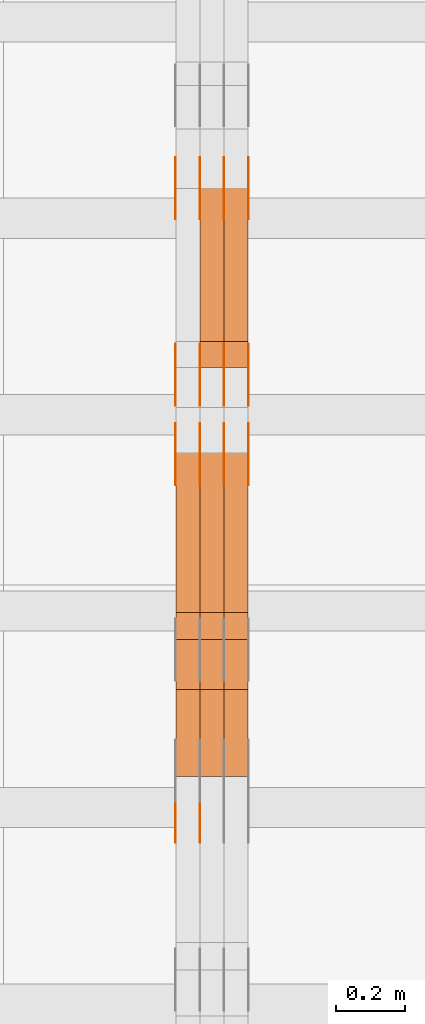
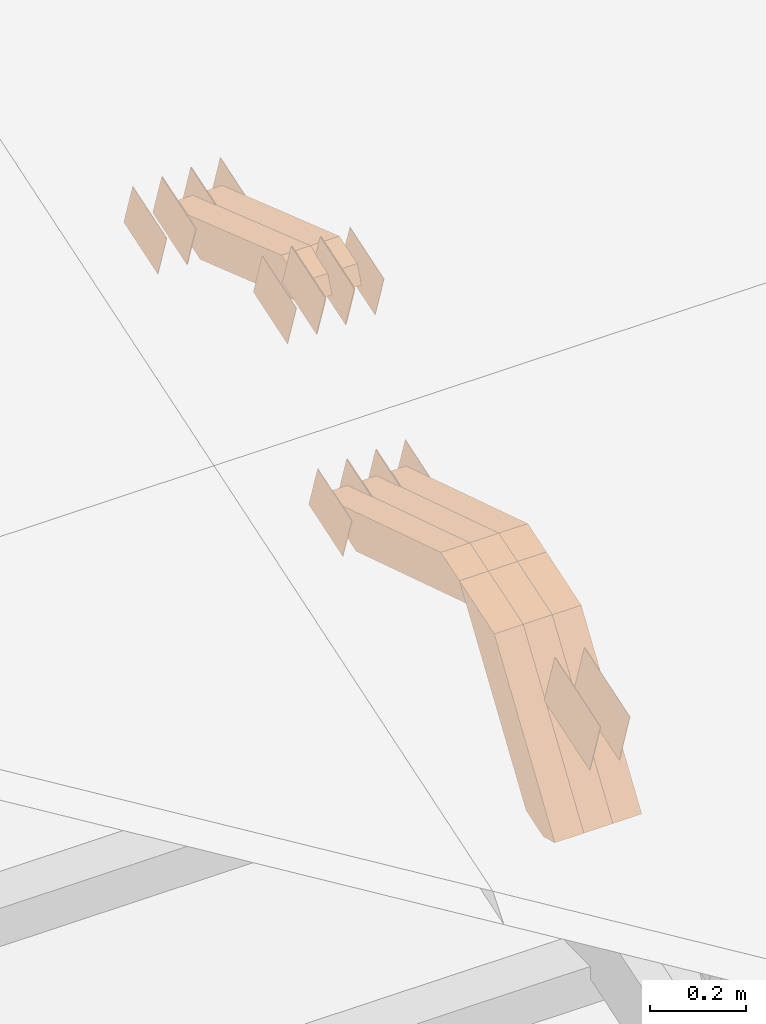
# One storey, part 269 of 385: 28 proxies.
"""IFC2X3 building model written with IfcOpenShell, lengths in millimetres."""

from ifc_helpers import new_model, entity, si_unit, converted_unit, derived_unit, direction, frame, origin, place, context, subcontext, project, spatial, polyline, outline, extrude, source, transform, mapped, material, type_object, type_shapes, element, save


model = new_model("IFC2X3")

# Units and contexts
model_context = context("Model", 3, precision=0.01, world=origin(), true_north=direction((6.12303176911189e-17, 1.0)))
body_context = subcontext(model_context, "Body", "Model", "MODEL_VIEW")
ifc_project = project(units=[si_unit("LENGTHUNIT", "METRE", prefix="MILLI"), si_unit("AREAUNIT", "SQUARE_METRE"), si_unit("VOLUMEUNIT", "CUBIC_METRE"), converted_unit("PLANEANGLEUNIT", "DEGREE", entity("IfcRatioMeasure", 0.0174532925199433), si_unit("PLANEANGLEUNIT", "RADIAN"), dimensions=[0, 0, 0, 0, 0, 0, 0]), si_unit("MASSUNIT", "GRAM", prefix="KILO"), derived_unit("MASSDENSITYUNIT", [(si_unit("MASSUNIT", "GRAM", prefix="KILO"), 1), (si_unit("LENGTHUNIT", "METRE"), -3)]), si_unit("TIMEUNIT", "SECOND"), si_unit("FREQUENCYUNIT", "HERTZ"), si_unit("THERMODYNAMICTEMPERATUREUNIT", "DEGREE_CELSIUS"), derived_unit("THERMALTRANSMITTANCEUNIT", [(si_unit("MASSUNIT", "GRAM", prefix="KILO"), 1), (si_unit("THERMODYNAMICTEMPERATUREUNIT", "KELVIN"), -1), (si_unit("TIMEUNIT", "SECOND"), -3)]), derived_unit("VOLUMETRICFLOWRATEUNIT", [(si_unit("LENGTHUNIT", "METRE"), 3), (si_unit("TIMEUNIT", "SECOND"), -1)]), si_unit("ELECTRICCURRENTUNIT", "AMPERE"), si_unit("ELECTRICVOLTAGEUNIT", "VOLT"), si_unit("POWERUNIT", "WATT"), si_unit("FORCEUNIT", "NEWTON", prefix="KILO"), si_unit("ILLUMINANCEUNIT", "LUX"), si_unit("LUMINOUSFLUXUNIT", "LUMEN"), si_unit("LUMINOUSINTENSITYUNIT", "CANDELA"), derived_unit("USERDEFINED", [(si_unit("MASSUNIT", "GRAM", prefix="KILO"), -1), (si_unit("LENGTHUNIT", "METRE"), -2), (si_unit("TIMEUNIT", "SECOND"), 3), (si_unit("LUMINOUSFLUXUNIT", "LUMEN"), 1)]), derived_unit("LINEARVELOCITYUNIT", [(si_unit("LENGTHUNIT", "METRE"), 1), (si_unit("TIMEUNIT", "SECOND"), -1)]), si_unit("PRESSUREUNIT", "PASCAL"), derived_unit("USERDEFINED", [(si_unit("LENGTHUNIT", "METRE"), -2), (si_unit("MASSUNIT", "GRAM", prefix="KILO"), 1), (si_unit("TIMEUNIT", "SECOND"), -2)])], contexts=[model_context])

# Site, building, storey
site_placement = place(None, origin())
site = spatial("IfcSite", under=ifc_project, at=site_placement, CompositionType="ELEMENT")
building_placement = place(site_placement, origin())
building = spatial("IfcBuilding", under=site, at=building_placement, CompositionType="ELEMENT")
storey_placement = place(building_placement, origin())
storey = spatial("IfcBuildingStorey", under=building, at=storey_placement, Name="Default", CompositionType="ELEMENT", Elevation=0.0)

# Proxies
ifc_material_1 = material(Name="IfcSurfaceStyle #551750")
building_element_proxy_type_1 = type_object("IfcBuildingElementProxyType", PredefinedType="NOTDEFINED", material=ifc_material_1)
shared_shape_1 = source(origin(), body_context, "Body", "SweptSolid", [
    extrude(outline(polyline([(-74.9998754286198, -60.0000016373433), (74.9998605591145, -60.0000016373433), (74.999875428618, 60.0000016373433), (-74.9998605591127, 60.0000016373433), (-74.9998754286198, -60.0000016373433)])), frame((75.0007059026038, 60.000210935219, 0.0), z_axis=(0.0, 0.0, 1.0), x_axis=(-1.0, 0.0, 0.0)), (0.0, 0.0, 1.0), 1.3),
])
type_shapes(building_element_proxy_type_1, [shared_shape_1])
proxy_1_placement = place(building_placement, frame((45386.3, 6760.15341914203, 1372.60670336718), z_axis=(-1.0, 0.0, 0.0), x_axis=(0.0, 0.951056516295124, 0.309016994375039)))
element("IfcBuildingElementProxy", 1, at=proxy_1_placement, inside=storey, type_object=building_element_proxy_type_1, material=ifc_material_1, context=body_context, shape_type="MappedRepresentation", body=[
    mapped(shared_shape_1, transform((0.0, 0.0, 0.0), scale=1.0)),
])
ifc_material_2 = material(Name="IfcSurfaceStyle #551693")
building_element_proxy_type_2 = type_object("IfcBuildingElementProxyType", PredefinedType="NOTDEFINED", material=ifc_material_2)
shared_shape_2 = source(origin(), body_context, "Body", "SweptSolid", [
    extrude(outline(polyline([(-74.9998754286198, -60.0000016373433), (74.9998605591145, -60.0000016373433), (74.999875428618, 60.0000016373433), (-74.9998605591127, 60.0000016373433), (-74.9998754286198, -60.0000016373433)])), frame((75.0007059026038, 60.000210935219, 0.0), z_axis=(0.0, 0.0, 1.0), x_axis=(-1.0, 0.0, 0.0)), (0.0, 0.0, 1.0), 1.3),
])
type_shapes(building_element_proxy_type_2, [shared_shape_2])
proxy_2_placement = place(building_placement, frame((45315.0, 6760.15341914203, 1372.60670336718), z_axis=(-1.0, 0.0, 0.0), x_axis=(0.0, 0.951056516295124, 0.309016994375039)))
element("IfcBuildingElementProxy", 2, at=proxy_2_placement, inside=storey, type_object=building_element_proxy_type_2, material=ifc_material_2, context=body_context, shape_type="MappedRepresentation", body=[
    mapped(shared_shape_2, transform((0.0, 0.0, 0.0), scale=1.0)),
])
ifc_material_3 = material(Name="IfcSurfaceStyle #551636")
building_element_proxy_type_3 = type_object("IfcBuildingElementProxyType", PredefinedType="NOTDEFINED", material=ifc_material_3)
shared_shape_3 = source(origin(), body_context, "Body", "SweptSolid", [
    extrude(outline(polyline([(-74.9998754286198, -60.0000016373433), (74.9998605591145, -60.0000016373433), (74.999875428618, 60.0000016373433), (-74.9998605591127, 60.0000016373433), (-74.9998754286198, -60.0000016373433)])), frame((75.0007059026038, 60.000210935219, 0.0), z_axis=(0.0, 0.0, 1.0), x_axis=(-1.0, 0.0, 0.0)), (0.0, 0.0, 1.0), 1.3),
])
type_shapes(building_element_proxy_type_3, [shared_shape_3])
proxy_3_placement = place(building_placement, frame((45316.3, 6760.15341914203, 1372.60670336718), z_axis=(-1.0, 0.0, 0.0), x_axis=(0.0, 0.951056516295124, 0.309016994375039)))
element("IfcBuildingElementProxy", 3, at=proxy_3_placement, inside=storey, type_object=building_element_proxy_type_3, material=ifc_material_3, context=body_context, shape_type="MappedRepresentation", body=[
    mapped(shared_shape_3, transform((0.0, 0.0, 0.0), scale=1.0)),
])
ifc_material_4 = material(Name="IfcSurfaceStyle #551579")
building_element_proxy_type_4 = type_object("IfcBuildingElementProxyType", PredefinedType="NOTDEFINED", material=ifc_material_4)
shared_shape_4 = source(origin(), body_context, "Body", "SweptSolid", [
    extrude(outline(polyline([(-74.9998754286198, -60.0000016373433), (74.9998605591145, -60.0000016373433), (74.999875428618, 60.0000016373433), (-74.9998605591127, 60.0000016373433), (-74.9998754286198, -60.0000016373433)])), frame((75.0007059026038, 60.000210935219, 0.0), z_axis=(0.0, 0.0, 1.0), x_axis=(-1.0, 0.0, 0.0)), (0.0, 0.0, 1.0), 1.29999999999999),
])
type_shapes(building_element_proxy_type_4, [shared_shape_4])
proxy_4_placement = place(building_placement, frame((45245.0, 6760.15341914203, 1372.60670336718), z_axis=(-1.0, 0.0, 0.0), x_axis=(0.0, 0.951056516295124, 0.309016994375039)))
element("IfcBuildingElementProxy", 4, at=proxy_4_placement, inside=storey, type_object=building_element_proxy_type_4, material=ifc_material_4, context=body_context, shape_type="MappedRepresentation", body=[
    mapped(shared_shape_4, transform((0.0, 0.0, 0.0), scale=1.0)),
])
ifc_material_5 = material(Name="IfcSurfaceStyle #551522")
building_element_proxy_type_5 = type_object("IfcBuildingElementProxyType", PredefinedType="NOTDEFINED", material=ifc_material_5)
shared_shape_5 = source(origin(), body_context, "Body", "SweptSolid", [
    extrude(outline(polyline([(-74.9998754286198, -60.0000016373433), (74.9998605591145, -60.0000016373433), (74.999875428618, 60.0000016373433), (-74.9998605591127, 60.0000016373433), (-74.9998754286198, -60.0000016373433)])), frame((75.0007059026038, 60.000210935219, 0.0), z_axis=(0.0, 0.0, 1.0), x_axis=(-1.0, 0.0, 0.0)), (0.0, 0.0, 1.0), 1.29999999999999),
])
type_shapes(building_element_proxy_type_5, [shared_shape_5])
proxy_5_placement = place(building_placement, frame((45246.3, 6760.15341914203, 1372.60670336718), z_axis=(-1.0, 0.0, 0.0), x_axis=(0.0, 0.951056516295124, 0.309016994375039)))
element("IfcBuildingElementProxy", 5, at=proxy_5_placement, inside=storey, type_object=building_element_proxy_type_5, material=ifc_material_5, context=body_context, shape_type="MappedRepresentation", body=[
    mapped(shared_shape_5, transform((0.0, 0.0, 0.0), scale=1.0)),
])
ifc_material_6 = material(Name="IfcSurfaceStyle #551465")
building_element_proxy_type_6 = type_object("IfcBuildingElementProxyType", PredefinedType="NOTDEFINED", material=ifc_material_6)
shared_shape_6 = source(origin(), body_context, "Body", "SweptSolid", [
    extrude(outline(polyline([(-74.9998754286198, -60.0000016373433), (74.9998605591145, -60.0000016373433), (74.999875428618, 60.0000016373433), (-74.9998605591127, 60.0000016373433), (-74.9998754286198, -60.0000016373433)])), frame((75.0007059026038, 60.000210935219, 0.0), z_axis=(0.0, 0.0, 1.0), x_axis=(-1.0, 0.0, 0.0)), (0.0, 0.0, 1.0), 1.29999999999999),
])
type_shapes(building_element_proxy_type_6, [shared_shape_6])
proxy_6_placement = place(building_placement, frame((45175.0, 6760.15341914203, 1372.60670336718), z_axis=(-1.0, 0.0, 0.0), x_axis=(0.0, 0.951056516295124, 0.309016994375039)))
element("IfcBuildingElementProxy", 6, at=proxy_6_placement, inside=storey, type_object=building_element_proxy_type_6, material=ifc_material_6, context=body_context, shape_type="MappedRepresentation", body=[
    mapped(shared_shape_6, transform((0.0, 0.0, 0.0), scale=1.0)),
])
ifc_material_7 = material(Name="IfcSurfaceStyle #545594")
building_element_proxy_type_7 = type_object("IfcBuildingElementProxyType", PredefinedType="NOTDEFINED", material=ifc_material_7)
shared_shape_7 = source(origin(), body_context, "Body", "SweptSolid", [
    extrude(outline(polyline([(-74.9998801438441, -60.0000306612856), (74.9998747047876, -60.0000306612856), (74.9998707133936, 60.0000306612856), (-74.9998652743371, 60.0000306612856), (-74.9998801438441, -60.0000306612856)])), frame((75.0000206139493, 60.0000306612856, 0.0), z_axis=(0.0, 0.0, 1.0), x_axis=(-1.0, 0.0, 0.0)), (0.0, 0.0, 1.0), 1.3),
])
type_shapes(building_element_proxy_type_7, [shared_shape_7])
proxy_7_placement = place(building_placement, frame((45386.3, 5987.08381858243, 1121.42116774683), z_axis=(-1.0, 0.0, 0.0), x_axis=(0.0, 0.951056516295124, 0.309016994375039)))
element("IfcBuildingElementProxy", 7, at=proxy_7_placement, inside=storey, type_object=building_element_proxy_type_7, material=ifc_material_7, context=body_context, shape_type="MappedRepresentation", body=[
    mapped(shared_shape_7, transform((0.0, 0.0, 0.0), scale=1.0)),
])
ifc_material_8 = material(Name="IfcSurfaceStyle #545537")
building_element_proxy_type_8 = type_object("IfcBuildingElementProxyType", PredefinedType="NOTDEFINED", material=ifc_material_8)
shared_shape_8 = source(origin(), body_context, "Body", "SweptSolid", [
    extrude(outline(polyline([(-74.9998801438441, -60.0000306612856), (74.9998747047876, -60.0000306612856), (74.9998707133936, 60.0000306612856), (-74.9998652743371, 60.0000306612856), (-74.9998801438441, -60.0000306612856)])), frame((75.0000206139493, 60.0000306612856, 0.0), z_axis=(0.0, 0.0, 1.0), x_axis=(-1.0, 0.0, 0.0)), (0.0, 0.0, 1.0), 1.3),
])
type_shapes(building_element_proxy_type_8, [shared_shape_8])
proxy_8_placement = place(building_placement, frame((45315.0, 5987.08381858243, 1121.42116774683), z_axis=(-1.0, 0.0, 0.0), x_axis=(0.0, 0.951056516295124, 0.309016994375039)))
element("IfcBuildingElementProxy", 8, at=proxy_8_placement, inside=storey, type_object=building_element_proxy_type_8, material=ifc_material_8, context=body_context, shape_type="MappedRepresentation", body=[
    mapped(shared_shape_8, transform((0.0, 0.0, 0.0), scale=1.0)),
])
ifc_material_9 = material(Name="IfcSurfaceStyle #545480")
building_element_proxy_type_9 = type_object("IfcBuildingElementProxyType", PredefinedType="NOTDEFINED", material=ifc_material_9)
shared_shape_9 = source(origin(), body_context, "Body", "SweptSolid", [
    extrude(outline(polyline([(-74.9998801438441, -60.0000306612856), (74.9998747047876, -60.0000306612856), (74.9998707133936, 60.0000306612856), (-74.9998652743371, 60.0000306612856), (-74.9998801438441, -60.0000306612856)])), frame((75.0000206139493, 60.0000306612856, 0.0), z_axis=(0.0, 0.0, 1.0), x_axis=(-1.0, 0.0, 0.0)), (0.0, 0.0, 1.0), 1.3),
])
type_shapes(building_element_proxy_type_9, [shared_shape_9])
proxy_9_placement = place(building_placement, frame((45316.3, 5987.08381858243, 1121.42116774683), z_axis=(-1.0, 0.0, 0.0), x_axis=(0.0, 0.951056516295124, 0.309016994375039)))
element("IfcBuildingElementProxy", 9, at=proxy_9_placement, inside=storey, type_object=building_element_proxy_type_9, material=ifc_material_9, context=body_context, shape_type="MappedRepresentation", body=[
    mapped(shared_shape_9, transform((0.0, 0.0, 0.0), scale=1.0)),
])
ifc_material_10 = material(Name="IfcSurfaceStyle #545423")
building_element_proxy_type_10 = type_object("IfcBuildingElementProxyType", PredefinedType="NOTDEFINED", material=ifc_material_10)
shared_shape_10 = source(origin(), body_context, "Body", "SweptSolid", [
    extrude(outline(polyline([(-74.9998801438441, -60.0000306612856), (74.9998747047876, -60.0000306612856), (74.9998707133936, 60.0000306612856), (-74.9998652743371, 60.0000306612856), (-74.9998801438441, -60.0000306612856)])), frame((75.0000206139493, 60.0000306612856, 0.0), z_axis=(0.0, 0.0, 1.0), x_axis=(-1.0, 0.0, 0.0)), (0.0, 0.0, 1.0), 1.29999999999999),
])
type_shapes(building_element_proxy_type_10, [shared_shape_10])
proxy_10_placement = place(building_placement, frame((45245.0, 5987.08381858243, 1121.42116774683), z_axis=(-1.0, 0.0, 0.0), x_axis=(0.0, 0.951056516295124, 0.309016994375039)))
element("IfcBuildingElementProxy", 10, at=proxy_10_placement, inside=storey, type_object=building_element_proxy_type_10, material=ifc_material_10, context=body_context, shape_type="MappedRepresentation", body=[
    mapped(shared_shape_10, transform((0.0, 0.0, 0.0), scale=1.0)),
])
ifc_material_11 = material(Name="IfcSurfaceStyle #545366")
building_element_proxy_type_11 = type_object("IfcBuildingElementProxyType", PredefinedType="NOTDEFINED", material=ifc_material_11)
shared_shape_11 = source(origin(), body_context, "Body", "SweptSolid", [
    extrude(outline(polyline([(-74.9998801438441, -60.0000306612856), (74.9998747047876, -60.0000306612856), (74.9998707133936, 60.0000306612856), (-74.9998652743371, 60.0000306612856), (-74.9998801438441, -60.0000306612856)])), frame((75.0000206139493, 60.0000306612856, 0.0), z_axis=(0.0, 0.0, 1.0), x_axis=(-1.0, 0.0, 0.0)), (0.0, 0.0, 1.0), 1.29999999999999),
])
type_shapes(building_element_proxy_type_11, [shared_shape_11])
proxy_11_placement = place(building_placement, frame((45246.3, 5987.08381858243, 1121.42116774683), z_axis=(-1.0, 0.0, 0.0), x_axis=(0.0, 0.951056516295124, 0.309016994375039)))
element("IfcBuildingElementProxy", 11, at=proxy_11_placement, inside=storey, type_object=building_element_proxy_type_11, material=ifc_material_11, context=body_context, shape_type="MappedRepresentation", body=[
    mapped(shared_shape_11, transform((0.0, 0.0, 0.0), scale=1.0)),
])
ifc_material_12 = material(Name="IfcSurfaceStyle #545309")
building_element_proxy_type_12 = type_object("IfcBuildingElementProxyType", PredefinedType="NOTDEFINED", material=ifc_material_12)
shared_shape_12 = source(origin(), body_context, "Body", "SweptSolid", [
    extrude(outline(polyline([(-74.9998801438441, -60.0000306612856), (74.9998747047876, -60.0000306612856), (74.9998707133936, 60.0000306612856), (-74.9998652743371, 60.0000306612856), (-74.9998801438441, -60.0000306612856)])), frame((75.0000206139493, 60.0000306612856, 0.0), z_axis=(0.0, 0.0, 1.0), x_axis=(-1.0, 0.0, 0.0)), (0.0, 0.0, 1.0), 1.29999999999999),
])
type_shapes(building_element_proxy_type_12, [shared_shape_12])
proxy_12_placement = place(building_placement, frame((45175.0, 5987.08381858243, 1121.42116774683), z_axis=(-1.0, 0.0, 0.0), x_axis=(0.0, 0.951056516295124, 0.309016994375039)))
element("IfcBuildingElementProxy", 12, at=proxy_12_placement, inside=storey, type_object=building_element_proxy_type_12, material=ifc_material_12, context=body_context, shape_type="MappedRepresentation", body=[
    mapped(shared_shape_12, transform((0.0, 0.0, 0.0), scale=1.0)),
])
ifc_material_13 = material(Name="IfcSurfaceStyle #541148")
building_element_proxy_type_13 = type_object("IfcBuildingElementProxyType", PredefinedType="NOTDEFINED", material=ifc_material_13)
shared_shape_13 = source(origin(), body_context, "Body", "SweptSolid", [
    extrude(outline(polyline([(-74.9998754286253, -60.0000016373506), (74.999860559109, -60.0000016373506), (74.9998754286235, 60.0000016373506), (-74.9998605591072, 60.0000016373506), (-74.9998754286253, -60.0000016373506)])), frame((75.0001009411744, 60.0000279841752, 0.0), z_axis=(0.0, 0.0, 1.0), x_axis=(-1.0, 0.0, 0.0)), (0.0, 0.0, 1.0), 1.3),
])
type_shapes(building_element_proxy_type_13, [shared_shape_13])
proxy_13_placement = place(building_placement, frame((45386.3, 6218.29662915453, 1523.23574463408), z_axis=(-1.0, 0.0, 0.0), x_axis=(0.0, 0.951056516295154, 0.309016994374948)))
element("IfcBuildingElementProxy", 13, at=proxy_13_placement, inside=storey, type_object=building_element_proxy_type_13, material=ifc_material_13, context=body_context, shape_type="MappedRepresentation", body=[
    mapped(shared_shape_13, transform((0.0, 0.0, 0.0), scale=1.0)),
])
ifc_material_14 = material(Name="IfcSurfaceStyle #541091")
building_element_proxy_type_14 = type_object("IfcBuildingElementProxyType", PredefinedType="NOTDEFINED", material=ifc_material_14)
shared_shape_14 = source(origin(), body_context, "Body", "SweptSolid", [
    extrude(outline(polyline([(-74.9998754286253, -60.0000016373506), (74.999860559109, -60.0000016373506), (74.9998754286235, 60.0000016373506), (-74.9998605591072, 60.0000016373506), (-74.9998754286253, -60.0000016373506)])), frame((75.0001009411744, 60.0000279841752, 0.0), z_axis=(0.0, 0.0, 1.0), x_axis=(-1.0, 0.0, 0.0)), (0.0, 0.0, 1.0), 1.3),
])
type_shapes(building_element_proxy_type_14, [shared_shape_14])
proxy_14_placement = place(building_placement, frame((45315.0, 6218.29662915453, 1523.23574463408), z_axis=(-1.0, 0.0, 0.0), x_axis=(0.0, 0.951056516295154, 0.309016994374948)))
element("IfcBuildingElementProxy", 14, at=proxy_14_placement, inside=storey, type_object=building_element_proxy_type_14, material=ifc_material_14, context=body_context, shape_type="MappedRepresentation", body=[
    mapped(shared_shape_14, transform((0.0, 0.0, 0.0), scale=1.0)),
])
ifc_material_15 = material(Name="IfcSurfaceStyle #541034")
building_element_proxy_type_15 = type_object("IfcBuildingElementProxyType", PredefinedType="NOTDEFINED", material=ifc_material_15)
shared_shape_15 = source(origin(), body_context, "Body", "SweptSolid", [
    extrude(outline(polyline([(-74.9998754286253, -60.0000016373506), (74.999860559109, -60.0000016373506), (74.9998754286235, 60.0000016373506), (-74.9998605591072, 60.0000016373506), (-74.9998754286253, -60.0000016373506)])), frame((75.0001009411744, 60.0000279841752, 0.0), z_axis=(0.0, 0.0, 1.0), x_axis=(-1.0, 0.0, 0.0)), (0.0, 0.0, 1.0), 1.3),
])
type_shapes(building_element_proxy_type_15, [shared_shape_15])
proxy_15_placement = place(building_placement, frame((45316.3, 6218.29662915453, 1523.23574463408), z_axis=(-1.0, 0.0, 0.0), x_axis=(0.0, 0.951056516295154, 0.309016994374948)))
element("IfcBuildingElementProxy", 15, at=proxy_15_placement, inside=storey, type_object=building_element_proxy_type_15, material=ifc_material_15, context=body_context, shape_type="MappedRepresentation", body=[
    mapped(shared_shape_15, transform((0.0, 0.0, 0.0), scale=1.0)),
])
ifc_material_16 = material(Name="IfcSurfaceStyle #540977")
building_element_proxy_type_16 = type_object("IfcBuildingElementProxyType", PredefinedType="NOTDEFINED", material=ifc_material_16)
shared_shape_16 = source(origin(), body_context, "Body", "SweptSolid", [
    extrude(outline(polyline([(-74.9998754286253, -60.0000016373506), (74.999860559109, -60.0000016373506), (74.9998754286235, 60.0000016373506), (-74.9998605591072, 60.0000016373506), (-74.9998754286253, -60.0000016373506)])), frame((75.0001009411744, 60.0000279841752, 0.0), z_axis=(0.0, 0.0, 1.0), x_axis=(-1.0, 0.0, 0.0)), (0.0, 0.0, 1.0), 1.29999999999999),
])
type_shapes(building_element_proxy_type_16, [shared_shape_16])
proxy_16_placement = place(building_placement, frame((45245.0, 6218.29662915453, 1523.23574463408), z_axis=(-1.0, 0.0, 0.0), x_axis=(0.0, 0.951056516295154, 0.309016994374948)))
element("IfcBuildingElementProxy", 16, at=proxy_16_placement, inside=storey, type_object=building_element_proxy_type_16, material=ifc_material_16, context=body_context, shape_type="MappedRepresentation", body=[
    mapped(shared_shape_16, transform((0.0, 0.0, 0.0), scale=1.0)),
])
ifc_material_17 = material(Name="IfcSurfaceStyle #540920")
building_element_proxy_type_17 = type_object("IfcBuildingElementProxyType", PredefinedType="NOTDEFINED", material=ifc_material_17)
shared_shape_17 = source(origin(), body_context, "Body", "SweptSolid", [
    extrude(outline(polyline([(-74.9998754286253, -60.0000016373506), (74.999860559109, -60.0000016373506), (74.9998754286235, 60.0000016373506), (-74.9998605591072, 60.0000016373506), (-74.9998754286253, -60.0000016373506)])), frame((75.0001009411744, 60.0000279841752, 0.0), z_axis=(0.0, 0.0, 1.0), x_axis=(-1.0, 0.0, 0.0)), (0.0, 0.0, 1.0), 1.29999999999999),
])
type_shapes(building_element_proxy_type_17, [shared_shape_17])
proxy_17_placement = place(building_placement, frame((45246.3, 6218.29662915453, 1523.23574463408), z_axis=(-1.0, 0.0, 0.0), x_axis=(0.0, 0.951056516295154, 0.309016994374948)))
element("IfcBuildingElementProxy", 17, at=proxy_17_placement, inside=storey, type_object=building_element_proxy_type_17, material=ifc_material_17, context=body_context, shape_type="MappedRepresentation", body=[
    mapped(shared_shape_17, transform((0.0, 0.0, 0.0), scale=1.0)),
])
ifc_material_18 = material(Name="IfcSurfaceStyle #540863")
building_element_proxy_type_18 = type_object("IfcBuildingElementProxyType", PredefinedType="NOTDEFINED", material=ifc_material_18)
shared_shape_18 = source(origin(), body_context, "Body", "SweptSolid", [
    extrude(outline(polyline([(-74.9998754286253, -60.0000016373506), (74.999860559109, -60.0000016373506), (74.9998754286235, 60.0000016373506), (-74.9998605591072, 60.0000016373506), (-74.9998754286253, -60.0000016373506)])), frame((75.0001009411744, 60.0000279841752, 0.0), z_axis=(0.0, 0.0, 1.0), x_axis=(-1.0, 0.0, 0.0)), (0.0, 0.0, 1.0), 1.29999999999999),
])
type_shapes(building_element_proxy_type_18, [shared_shape_18])
proxy_18_placement = place(building_placement, frame((45175.0, 6218.29662915453, 1523.23574463408), z_axis=(-1.0, 0.0, 0.0), x_axis=(0.0, 0.951056516295154, 0.309016994374948)))
element("IfcBuildingElementProxy", 18, at=proxy_18_placement, inside=storey, type_object=building_element_proxy_type_18, material=ifc_material_18, context=body_context, shape_type="MappedRepresentation", body=[
    mapped(shared_shape_18, transform((0.0, 0.0, 0.0), scale=1.0)),
])
ifc_material_19 = material(Name="IfcSurfaceStyle #536474")
building_element_proxy_type_19 = type_object("IfcBuildingElementProxyType", PredefinedType="NOTDEFINED", material=ifc_material_19)
shared_shape_19 = source(origin(), body_context, "Body", "SweptSolid", [
    extrude(outline(polyline([(-99.9996257846169, -71.999973710258), (100.000009625089, -71.999973710258), (99.9996257846187, 71.999973710258), (-100.000009625091, 71.999973710258), (-99.9996257846169, -71.999973710258)])), frame((100.000083496635, 72.0000008245779, 0.0), z_axis=(0.0, 0.0, 1.0), x_axis=(-1.0, 0.0, 0.0)), (0.0, 0.0, 1.0), 1.29999999999998),
])
type_shapes(building_element_proxy_type_19, [shared_shape_19])
proxy_19_placement = place(building_placement, frame((45246.3, 4947.73195917317, 1225.53937157357), z_axis=(-1.0, 0.0, 0.0), x_axis=(0.0, 0.951056516295154, 0.309016994374948)))
element("IfcBuildingElementProxy", 19, at=proxy_19_placement, inside=storey, type_object=building_element_proxy_type_19, material=ifc_material_19, context=body_context, shape_type="MappedRepresentation", body=[
    mapped(shared_shape_19, transform((0.0, 0.0, 0.0), scale=1.0)),
])
ifc_material_20 = material(Name="IfcSurfaceStyle #536417")
building_element_proxy_type_20 = type_object("IfcBuildingElementProxyType", PredefinedType="NOTDEFINED", material=ifc_material_20)
shared_shape_20 = source(origin(), body_context, "Body", "SweptSolid", [
    extrude(outline(polyline([(-99.9996257846169, -71.999973710258), (100.000009625089, -71.999973710258), (99.9996257846187, 71.999973710258), (-100.000009625091, 71.999973710258), (-99.9996257846169, -71.999973710258)])), frame((100.000083496635, 72.0000008245779, 0.0), z_axis=(0.0, 0.0, 1.0), x_axis=(-1.0, 0.0, 0.0)), (0.0, 0.0, 1.0), 1.29999999999999),
])
type_shapes(building_element_proxy_type_20, [shared_shape_20])
proxy_20_placement = place(building_placement, frame((45175.0, 4947.73195917317, 1225.53937157357), z_axis=(-1.0, 0.0, 0.0), x_axis=(0.0, 0.951056516295154, 0.309016994374948)))
element("IfcBuildingElementProxy", 20, at=proxy_20_placement, inside=storey, type_object=building_element_proxy_type_20, material=ifc_material_20, context=body_context, shape_type="MappedRepresentation", body=[
    mapped(shared_shape_20, transform((0.0, 0.0, 0.0), scale=1.0)),
])
ifc_material_21 = material(Name="IfcSurfaceStyle #528152")
building_element_proxy_type_21 = type_object("IfcBuildingElementProxyType", Name="T1-W19 528150", PredefinedType="NOTDEFINED", material=ifc_material_21)
shared_shape_21 = source(origin(), body_context, "Body", "SweptSolid", [
    extrude(outline(polyline([(-234.986199656822, -47.5000587840676), (221.224626701627, -47.5000587840676), (219.29748584664, -9.04449542012076e-05), (156.014457007826, 47.5001040065446), (-361.550369899272, 47.5001040065447), (-234.986199656822, -47.5000587840676)])), frame((221.224626701627, 47.5001108598228, 0.0), z_axis=(0.0, 0.0, 1.0), x_axis=(-1.0, 0.0, 0.0)), (0.0, 0.0, 1.0), 70.0),
])
type_shapes(building_element_proxy_type_21, [shared_shape_21])
proxy_21_placement = place(building_placement, frame((45385.0, 6342.40425701111, 1541.63383639481), z_axis=(-1.0, 0.0, 0.0), x_axis=(0.0, 0.9461301511345, -0.323786561046329)))
element("IfcBuildingElementProxy", 21, at=proxy_21_placement, inside=storey, type_object=building_element_proxy_type_21, material=ifc_material_21, Name="T1-W19", context=body_context, shape_type="MappedRepresentation", body=[
    mapped(shared_shape_21, transform((0.0, 0.0, 0.0), scale=1.0)),
])
ifc_material_22 = material(Name="IfcSurfaceStyle #528086")
building_element_proxy_type_22 = type_object("IfcBuildingElementProxyType", Name="T1-W19 528084", PredefinedType="NOTDEFINED", material=ifc_material_22)
shared_shape_22 = source(origin(), body_context, "Body", "SweptSolid", [
    extrude(outline(polyline([(-234.986199656822, -47.5000587840676), (221.224626701627, -47.5000587840676), (219.29748584664, -9.04449542012076e-05), (156.014457007826, 47.5001040065446), (-361.550369899272, 47.5001040065447), (-234.986199656822, -47.5000587840676)])), frame((221.224626701627, 47.5001108598228, 0.0), z_axis=(0.0, 0.0, 1.0), x_axis=(-1.0, 0.0, 0.0)), (0.0, 0.0, 1.0), 70.0),
])
type_shapes(building_element_proxy_type_22, [shared_shape_22])
proxy_22_placement = place(building_placement, frame((45315.0, 6342.40425701111, 1541.63383639481), z_axis=(-1.0, 0.0, 0.0), x_axis=(0.0, 0.9461301511345, -0.323786561046329)))
element("IfcBuildingElementProxy", 22, at=proxy_22_placement, inside=storey, type_object=building_element_proxy_type_22, material=ifc_material_22, Name="T1-W19", context=body_context, shape_type="MappedRepresentation", body=[
    mapped(shared_shape_22, transform((0.0, 0.0, 0.0), scale=1.0)),
])
ifc_material_23 = material(Name="IfcSurfaceStyle #527360")
building_element_proxy_type_23 = type_object("IfcBuildingElementProxyType", Name="T1-W15 527358", PredefinedType="NOTDEFINED", material=ifc_material_23)
shared_shape_23 = source(origin(), body_context, "Body", "SweptSolid", [
    extrude(outline(polyline([(-243.398341390642, -47.5000170814535), (237.775741169608, -47.5000170814535), (224.054017709933, 0.000127777485579883), (157.692261395711, 47.4999531927108), (-376.12367888461, 47.4999531927107), (-243.398341390642, -47.5000170814535)])), frame((237.77637044506, 47.5003404768297, 0.0), z_axis=(0.0, 0.0, 1.0), x_axis=(-1.0, 0.0, 0.0)), (0.0, 0.0, 1.0), 70.0),
])
type_shapes(building_element_proxy_type_23, [shared_shape_23])
proxy_23_placement = place(building_placement, frame((45385.0, 5540.23242178143, 1288.84274826279), z_axis=(-1.0, 0.0, 0.0), x_axis=(0.0, 0.95322291386448, -0.302268219440466)))
element("IfcBuildingElementProxy", 23, at=proxy_23_placement, inside=storey, type_object=building_element_proxy_type_23, material=ifc_material_23, Name="T1-W15", context=body_context, shape_type="MappedRepresentation", body=[
    mapped(shared_shape_23, transform((0.0, 0.0, 0.0), scale=1.0)),
])
ifc_material_24 = material(Name="IfcSurfaceStyle #527294")
building_element_proxy_type_24 = type_object("IfcBuildingElementProxyType", Name="T1-W15 527292", PredefinedType="NOTDEFINED", material=ifc_material_24)
shared_shape_24 = source(origin(), body_context, "Body", "SweptSolid", [
    extrude(outline(polyline([(-243.398341390642, -47.5000170814535), (237.775741169608, -47.5000170814535), (224.054017709933, 0.000127777485579883), (157.692261395711, 47.4999531927108), (-376.12367888461, 47.4999531927107), (-243.398341390642, -47.5000170814535)])), frame((237.77637044506, 47.5003404768297, 0.0), z_axis=(0.0, 0.0, 1.0), x_axis=(-1.0, 0.0, 0.0)), (0.0, 0.0, 1.0), 70.0),
])
type_shapes(building_element_proxy_type_24, [shared_shape_24])
proxy_24_placement = place(building_placement, frame((45315.0, 5540.23242178143, 1288.84274826279), z_axis=(-1.0, 0.0, 0.0), x_axis=(0.0, 0.95322291386448, -0.302268219440466)))
element("IfcBuildingElementProxy", 24, at=proxy_24_placement, inside=storey, type_object=building_element_proxy_type_24, material=ifc_material_24, Name="T1-W15", context=body_context, shape_type="MappedRepresentation", body=[
    mapped(shared_shape_24, transform((0.0, 0.0, 0.0), scale=1.0)),
])
ifc_material_25 = material(Name="IfcSurfaceStyle #527228")
building_element_proxy_type_25 = type_object("IfcBuildingElementProxyType", Name="T1-W15 527226", PredefinedType="NOTDEFINED", material=ifc_material_25)
shared_shape_25 = source(origin(), body_context, "Body", "SweptSolid", [
    extrude(outline(polyline([(-243.398341390642, -47.5000170814535), (237.775741169608, -47.5000170814535), (224.054017709933, 0.000127777485579883), (157.692261395711, 47.4999531927108), (-376.12367888461, 47.4999531927107), (-243.398341390642, -47.5000170814535)])), frame((237.77637044506, 47.5003404768297, 0.0), z_axis=(0.0, 0.0, 1.0), x_axis=(-1.0, 0.0, 0.0)), (0.0, 0.0, 1.0), 70.0),
])
type_shapes(building_element_proxy_type_25, [shared_shape_25])
proxy_25_placement = place(building_placement, frame((45245.0, 5540.23242178143, 1288.84274826279), z_axis=(-1.0, 0.0, 0.0), x_axis=(0.0, 0.95322291386448, -0.302268219440466)))
element("IfcBuildingElementProxy", 25, at=proxy_25_placement, inside=storey, type_object=building_element_proxy_type_25, material=ifc_material_25, Name="T1-W15", context=body_context, shape_type="MappedRepresentation", body=[
    mapped(shared_shape_25, transform((0.0, 0.0, 0.0), scale=1.0)),
])
ifc_material_26 = material(Name="IfcSurfaceStyle #526964")
building_element_proxy_type_26 = type_object("IfcBuildingElementProxyType", Name="T1-W22 526962", PredefinedType="NOTDEFINED", material=ifc_material_26)
shared_shape_26 = source(origin(), body_context, "Body", "SweptSolid", [
    extrude(outline(polyline([(-351.940486061686, -47.5005995570677), (149.451602529695, -47.5005995570676), (209.614029773051, 0.000108554198836676), (224.491670779786, 47.5010029530092), (-231.616817020846, 47.5000876069273), (-351.940486061686, -47.5005995570677)])), frame((224.491766107217, 47.5005524294596, 0.0), z_axis=(0.0, 0.0, 1.0), x_axis=(-1.0, 2.00686044286885e-06, 0.0)), (0.0, 0.0, 1.0), 70.0),
])
type_shapes(building_element_proxy_type_26, [shared_shape_26])
proxy_26_placement = place(building_placement, frame((45385.0, 5140.03125000001, 812.615600585936), z_axis=(-1.0, 0.0, 0.0), x_axis=(0.0, 0.554956576676696, 0.831879316970486)))
element("IfcBuildingElementProxy", 26, at=proxy_26_placement, inside=storey, type_object=building_element_proxy_type_26, material=ifc_material_26, Name="T1-W22", context=body_context, shape_type="MappedRepresentation", body=[
    mapped(shared_shape_26, transform((0.0, 0.0, 0.0), scale=1.0)),
])
ifc_material_27 = material(Name="IfcSurfaceStyle #526898")
building_element_proxy_type_27 = type_object("IfcBuildingElementProxyType", Name="T1-W22 526896", PredefinedType="NOTDEFINED", material=ifc_material_27)
shared_shape_27 = source(origin(), body_context, "Body", "SweptSolid", [
    extrude(outline(polyline([(-351.940486061686, -47.5005995570677), (149.451602529695, -47.5005995570676), (209.614029773051, 0.000108554198836676), (224.491670779786, 47.5010029530092), (-231.616817020846, 47.5000876069273), (-351.940486061686, -47.5005995570677)])), frame((224.491766107217, 47.5005524294596, 0.0), z_axis=(0.0, 0.0, 1.0), x_axis=(-1.0, 2.00686044286885e-06, 0.0)), (0.0, 0.0, 1.0), 70.0),
])
type_shapes(building_element_proxy_type_27, [shared_shape_27])
proxy_27_placement = place(building_placement, frame((45315.0, 5140.03125000001, 812.615600585936), z_axis=(-1.0, 0.0, 0.0), x_axis=(0.0, 0.554956576676696, 0.831879316970486)))
element("IfcBuildingElementProxy", 27, at=proxy_27_placement, inside=storey, type_object=building_element_proxy_type_27, material=ifc_material_27, Name="T1-W22", context=body_context, shape_type="MappedRepresentation", body=[
    mapped(shared_shape_27, transform((0.0, 0.0, 0.0), scale=1.0)),
])
ifc_material_28 = material(Name="IfcSurfaceStyle #526832")
building_element_proxy_type_28 = type_object("IfcBuildingElementProxyType", Name="T1-W22 526830", PredefinedType="NOTDEFINED", material=ifc_material_28)
shared_shape_28 = source(origin(), body_context, "Body", "SweptSolid", [
    extrude(outline(polyline([(-351.940486061686, -47.5005995570677), (149.451602529695, -47.5005995570676), (209.614029773051, 0.000108554198836676), (224.491670779786, 47.5010029530092), (-231.616817020846, 47.5000876069273), (-351.940486061686, -47.5005995570677)])), frame((224.491766107217, 47.5005524294596, 0.0), z_axis=(0.0, 0.0, 1.0), x_axis=(-1.0, 2.00686044286885e-06, 0.0)), (0.0, 0.0, 1.0), 70.0),
])
type_shapes(building_element_proxy_type_28, [shared_shape_28])
proxy_28_placement = place(building_placement, frame((45245.0, 5140.03125000001, 812.615600585936), z_axis=(-1.0, 0.0, 0.0), x_axis=(0.0, 0.554956576676696, 0.831879316970486)))
element("IfcBuildingElementProxy", 28, at=proxy_28_placement, inside=storey, type_object=building_element_proxy_type_28, material=ifc_material_28, Name="T1-W22", context=body_context, shape_type="MappedRepresentation", body=[
    mapped(shared_shape_28, transform((0.0, 0.0, 0.0), scale=1.0)),
])

save(model, "model.ifc")
